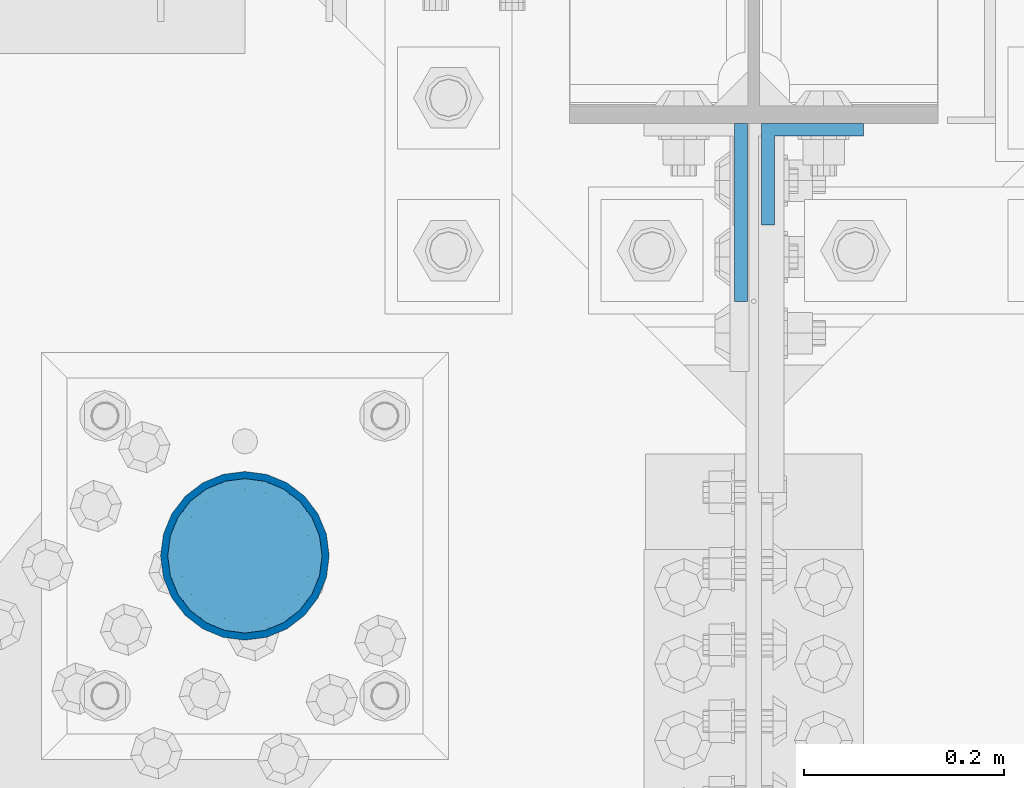
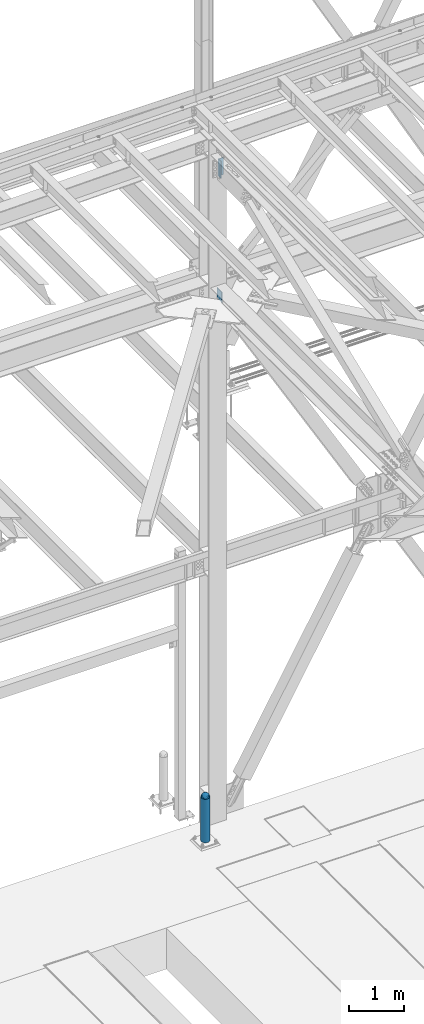
# One storey, part 1584 of 3843: 4 columns, 4 elements without a shape of their own.
"""IFC2X3 building model written with IfcOpenShell, lengths in millimetres."""

from ifc_helpers import new_model, si_unit, frame, origin_with_axes, place, context, subcontext, project, spatial, faceted_brep, material, type_object, element, aggregate, save


model = new_model("IFC2X3")

# Units and contexts
model_context = context("Model", 3, precision=1e-05, world=origin_with_axes())
body_context = subcontext(model_context, "Body", "Model", "MODEL_VIEW")
ifc_project = project(units=[si_unit("LENGTHUNIT", "METRE", prefix="MILLI"), si_unit("AREAUNIT", "SQUARE_METRE"), si_unit("VOLUMEUNIT", "CUBIC_METRE"), si_unit("MASSUNIT", "GRAM", prefix="KILO"), si_unit("TIMEUNIT", "SECOND"), si_unit("PLANEANGLEUNIT", "RADIAN"), si_unit("SOLIDANGLEUNIT", "STERADIAN"), si_unit("THERMODYNAMICTEMPERATUREUNIT", "DEGREE_CELSIUS"), si_unit("LUMINOUSINTENSITYUNIT", "LUMEN")], contexts=[model_context])

# Site, building, storey
site_placement = place(None, origin_with_axes())
site = spatial("IfcSite", under=ifc_project, at=site_placement, CompositionType="ELEMENT")
building_placement = place(site_placement, origin_with_axes())
building = spatial("IfcBuilding", under=site, at=building_placement, Name="Undefined", CompositionType="ELEMENT")
storey_placement = place(building_placement, origin_with_axes())
storey = spatial("IfcBuildingStorey", under=building, at=storey_placement, Name="Undefined", CompositionType="ELEMENT", Elevation=0.0)

# Assembly, column
assembly_1_placement = place(storey_placement, origin_with_axes())
assembly_1 = element("IfcElementAssembly", 1, at=assembly_1_placement, inside=storey, Name="CONC. FILL", AssemblyPlace="NOTDEFINED", PredefinedType="REINFORCEMENT_UNIT")
ifc_material_1 = material(Name="CONCRETE/1500")
column_type_1 = type_object("IfcColumnType", PredefinedType="NOTDEFINED")
column_1_placement = place(assembly_1_placement, frame((48488.6, 91605.1, 31411.8625), z_axis=(-1.0, 0.0, 0.0), x_axis=(0.0, 0.0, 1.0)))
column_1 = element("IfcColumn", 2, at=column_1_placement, type_object=column_type_1, material=ifc_material_1, Name="CONC. FILL", context=body_context, shape_type="Brep", body=[
    faceted_brep([(0.0, 0.0, 2.0), (0.0, -0.619999999995343, 1.89999999999964), (3.36549999999988, -7.1422259999963, 21.9814139999999), (3.36549999999988, 0.0, 23.1139999999996), (0.0, -1.17999999999302, 1.6200000000008), (3.36549999999988, -13.5910319999966, 18.6992260000006), (0.0, -1.61999999999534, 1.18000000000029), (3.36549999999988, -18.699225999997, 13.5910320000003), (0.0, -1.89999999999418, 0.6200000000008), (3.36549999999988, -21.9814139999944, 7.14222599999994), (0.0, -2.0, 0.0), (3.36549999999988, -23.1140000000014, 0.0), (0.0, -1.89999999999418, -0.6200000000008), (3.36549999999988, -21.9814139999944, -7.14222599999994), (0.0, -1.61999999999534, -1.18000000000029), (3.36549999999988, -18.699225999997, -13.5910320000003), (0.0, -1.17999999999302, -1.6200000000008), (3.36549999999988, -13.5910319999966, -18.6992260000006), (0.0, -0.619999999995343, -1.89999999999964), (3.36549999999988, -7.1422259999963, -21.9814139999999), (0.0, 0.0, -2.0), (3.36549999999988, 0.0, -23.1139999999996), (0.0, 0.619999999995343, -1.89999999999964), (3.36549999999988, 7.1422259999963, -21.9814139999999), (0.0, 1.17999999999302, -1.6200000000008), (3.36549999999988, 13.5910319999966, -18.6992260000006), (0.0, 1.61999999999534, -1.18000000000029), (3.36549999999988, 18.699225999997, -13.5910320000003), (0.0, 1.89999999999418, -0.6200000000008), (3.36549999999988, 21.9814139999944, -7.14222599999994), (0.0, 2.0, 0.0), (3.36549999999988, 23.1140000000014, 0.0), (0.0, 1.89999999999418, 0.6200000000008), (3.36549999999988, 21.9814139999944, 7.14222599999994), (0.0, 1.61999999999534, 1.18000000000029), (3.36549999999988, 18.699225999997, 13.5910320000003), (0.0, 1.17999999999302, 1.6200000000008), (3.36549999999988, 13.5910319999966, 18.6992260000006), (0.0, 0.619999999995343, 1.89999999999964), (3.36549999999988, 7.1422259999963, 21.9814139999999), (8.41374999999971, -11.1214661999984, 34.2282018000005), (8.41374999999971, 0.0, 35.9917999999998), (8.41374999999971, -21.1631784000056, 29.1173662000001), (8.41374999999971, -29.1173661999928, 21.1631784000001), (8.41374999999971, -34.2282017999969, 11.1214662000002), (8.41374999999971, -35.9918000000034, 0.0), (8.41374999999971, -34.2282017999969, -11.1214662000002), (8.41374999999971, -29.1173661999928, -21.1631784000001), (8.41374999999971, -21.1631784000056, -29.1173662000001), (8.41374999999971, -11.1214661999984, -34.2282018000005), (8.41374999999971, 0.0, -35.9917999999998), (8.41374999999971, 11.1214661999984, -34.2282018000005), (8.41374999999971, 21.1631784000056, -29.1173662000001), (8.41374999999971, 29.1173661999928, -21.1631784000001), (8.41374999999971, 34.2282017999969, -11.1214662000002), (8.41374999999971, 35.9918000000034, 0.0), (8.41374999999971, 34.2282017999969, 11.1214662000002), (8.41374999999971, 29.1173661999928, 21.1631784000001), (8.41374999999971, 21.1631784000056, 29.1173662000001), (8.41374999999971, 11.1214661999984, 34.2282018000005), (16.8274999999994, -15.3047700000025, 47.1030300000002), (16.8274999999994, 0.0, 49.5300000000007), (16.8274999999994, -29.1236400000053, 40.0697700000001), (16.8274999999994, -40.0697700000019, 29.1236399999998), (16.8274999999994, -47.1030299999984, 15.3047700000006), (16.8274999999994, -49.5299999999988, 0.0), (16.8274999999994, -47.1030299999984, -15.3047700000006), (16.8274999999994, -40.0697700000019, -29.1236399999998), (16.8274999999994, -29.1236400000053, -40.0697700000001), (16.8274999999994, -15.3047700000025, -47.1030300000002), (16.8274999999994, 0.0, -49.5300000000007), (16.8274999999994, 15.3047700000025, -47.1030300000002), (16.8274999999994, 29.1236400000053, -40.0697700000001), (16.8274999999994, 40.0697700000019, -29.1236399999998), (16.8274999999994, 47.1030299999984, -15.3047700000006), (16.8274999999994, 49.5299999999988, 0.0), (16.8274999999994, 47.1030299999984, 15.3047700000006), (16.8274999999994, 40.0697700000019, 29.1236399999998), (16.8274999999994, 29.1236400000053, 40.0697700000001), (16.8274999999994, 15.3047700000025, 47.1030300000002), (33.6549999999988, -20.4063599999936, 62.8040400000009), (33.6549999999988, 0.0, 66.0400000000009), (33.6549999999988, -38.831520000007, 53.4263599999995), (33.6549999999988, -53.4263599999977, 38.8315199999997), (33.6549999999988, -62.8040400000027, 20.4063600000009), (33.6549999999988, -66.0399999999936, 0.0), (33.6549999999988, -62.8040400000027, -20.4063600000009), (33.6549999999988, -53.4263599999977, -38.8315199999997), (33.6549999999988, -38.831520000007, -53.4263599999995), (33.6549999999988, -20.4063599999936, -62.8040400000009), (33.6549999999988, 0.0, -66.0400000000009), (33.6549999999988, 20.4063599999936, -62.8040400000009), (33.6549999999988, 38.831520000007, -53.4263599999995), (33.6549999999988, 53.4263599999977, -38.8315199999997), (33.6549999999988, 62.8040400000027, -20.4063600000009), (33.6549999999988, 66.0399999999936, 0.0), (33.6549999999988, 62.8040400000027, 20.4063600000009), (33.6549999999988, 53.4263599999977, 38.8315199999997), (33.6549999999988, 38.831520000007, 53.4263599999995), (33.6549999999988, 20.4063599999936, 62.8040400000009), (50.4824999999983, -23.3907901500061, 71.9891308499991), (50.4824999999983, 0.0, 75.6983500000006), (50.4824999999983, -44.5106298000028, 61.23996515), (50.4824999999983, -61.2399651500018, 44.5106297999992), (50.4824999999983, -71.9891308499937, 23.3907901500006), (50.4824999999983, -75.698350000006, 0.0), (50.4824999999983, -71.9891308499937, -23.3907901500006), (50.4824999999983, -61.2399651500018, -44.5106297999992), (50.4824999999983, -44.5106298000028, -61.23996515), (50.4824999999983, -23.3907901500061, -71.9891308499991), (50.4824999999983, 0.0, -75.6983500000006), (50.4824999999983, 23.3907901500061, -71.9891308499991), (50.4824999999983, 44.5106298000028, -61.23996515), (50.4824999999983, 61.2399651500018, -44.5106297999992), (50.4824999999983, 71.9891308499937, -23.3907901500006), (50.4824999999983, 75.698350000006, 0.0), (50.4824999999983, 71.9891308499937, 23.3907901500006), (50.4824999999983, 61.2399651500018, 44.5106297999992), (50.4824999999983, 44.5106298000028, 61.23996515), (50.4824999999983, 23.3907901500061, 71.9891308499991), (67.3099999999977, -24.9977910000016, 76.9349490000004), (67.3099999999977, 0.0, 80.8989999999994), (67.3099999999977, -47.5686120000028, 65.4472910000004), (67.3099999999977, -65.447291000004, 47.5686119999991), (67.3099999999977, -76.9349490000022, 24.9977909999998), (67.3099999999977, -80.8990000000049, 0.0), (67.3099999999977, -76.9349490000022, -24.9977909999998), (67.3099999999977, -65.447291000004, -47.5686119999991), (67.3099999999977, -47.5686120000028, -65.4472910000004), (67.3099999999977, -24.9977910000016, -76.9349490000004), (67.3099999999977, 0.0, -80.8989999999994), (67.3099999999977, 24.9977910000016, -76.9349490000004), (67.3099999999977, 47.5686120000028, -65.4472910000004), (67.3099999999977, 65.447291000004, -47.5686119999991), (67.3099999999977, 76.9349490000022, -24.9977909999998), (67.3099999999977, 80.8990000000049, 0.0), (67.3099999999977, 76.9349490000022, 24.9977909999998), (67.3099999999977, 65.447291000004, 47.5686119999991), (67.3099999999977, 47.5686120000028, 65.4472910000004), (67.3099999999977, 24.9977910000016, 76.9349490000004), (84.1374999999935, -25.5079499999993, 78.5050499999998), (84.1374999999935, 0.0, 82.5499999999993), (84.1374999999935, -48.5393999999942, 66.7829500000007), (84.1374999999935, -66.7829499999934, 48.5393999999997), (84.1374999999935, -78.505050000007, 25.5079499999993), (84.1374999999935, -82.5500000000029, 0.0), (84.1374999999935, -78.505050000007, -25.5079499999993), (84.1374999999935, -66.7829499999934, -48.5393999999997), (84.1374999999935, -48.5393999999942, -66.7829500000007), (84.1374999999935, -25.5079499999993, -78.5050499999998), (84.1374999999935, 0.0, -82.5499999999993), (84.1374999999935, 25.5079499999993, -78.5050499999998), (84.1374999999935, 48.5393999999942, -66.7829500000007), (84.1374999999935, 66.7829499999934, -48.5393999999997), (84.1374999999935, 78.505050000007, -25.5079499999993), (84.1374999999935, 82.5500000000029, 0.0), (84.1374999999935, 78.505050000007, 25.5079499999993), (84.1374999999935, 66.7829499999934, 48.5393999999997), (84.1374999999935, 48.5393999999942, 66.7829500000007), (84.1374999999935, 25.5079499999993, 78.5050499999998), (100.964999999993, -24.9977910000016, 76.9349490000004), (100.964999999993, 0.0, 80.8989999999994), (100.964999999993, -47.5686120000028, 65.4472910000004), (100.964999999993, -65.447291000004, 47.5686119999991), (100.964999999993, -76.9349490000022, 24.9977909999998), (100.964999999993, -80.8990000000049, 0.0), (100.964999999993, -76.9349490000022, -24.9977909999998), (100.964999999993, -65.447291000004, -47.5686119999991), (100.964999999993, -47.5686120000028, -65.4472910000004), (100.964999999993, -24.9977910000016, -76.9349490000004), (100.964999999993, 0.0, -80.8989999999994), (100.964999999993, 24.9977910000016, -76.9349490000004), (100.964999999993, 47.5686120000028, -65.4472910000004), (100.964999999993, 65.447291000004, -47.5686119999991), (100.964999999993, 76.9349490000022, -24.9977909999998), (100.964999999993, 80.8990000000049, 0.0), (100.964999999993, 76.9349490000022, 24.9977909999998), (100.964999999993, 65.447291000004, 47.5686119999991), (100.964999999993, 47.5686120000028, 65.4472910000004), (100.964999999993, 24.9977910000016, 76.9349490000004), (117.792499999992, -23.3907901500061, 71.9891308499991), (117.792499999992, 0.0, 75.6983500000006), (117.792499999992, -44.5106298000028, 61.23996515), (117.792499999992, -61.2399651500018, 44.5106297999992), (117.792499999992, -71.9891308499937, 23.3907901500006), (117.792499999992, -75.698350000006, 0.0), (117.792499999992, -71.9891308499937, -23.3907901500006), (117.792499999992, -61.2399651500018, -44.5106297999992), (117.792499999992, -44.5106298000028, -61.23996515), (117.792499999992, -23.3907901500061, -71.9891308499991), (117.792499999992, 0.0, -75.6983500000006), (117.792499999992, 23.3907901500061, -71.9891308499991), (117.792499999992, 44.5106298000028, -61.23996515), (117.792499999992, 61.2399651500018, -44.5106297999992), (117.792499999992, 71.9891308499937, -23.3907901500006), (117.792499999992, 75.698350000006, 0.0), (117.792499999992, 71.9891308499937, 23.3907901500006), (117.792499999992, 61.2399651500018, 44.5106297999992), (117.792499999992, 44.5106298000028, 61.23996515), (117.792499999992, 23.3907901500061, 71.9891308499991), (134.619999999992, -20.4063599999936, 62.8040400000009), (134.619999999992, 0.0, 66.0400000000009), (134.619999999992, -38.831520000007, 53.4263599999995), (134.619999999992, -53.4263599999977, 38.8315199999997), (134.619999999992, -62.8040400000027, 20.4063600000009), (134.619999999992, -66.0399999999936, 0.0), (134.619999999992, -62.8040400000027, -20.4063600000009), (134.619999999992, -53.4263599999977, -38.8315199999997), (134.619999999992, -38.831520000007, -53.4263599999995), (134.619999999992, -20.4063599999936, -62.8040400000009), (134.619999999992, 0.0, -66.0400000000009), (134.619999999992, 20.4063599999936, -62.8040400000009), (134.619999999992, 38.831520000007, -53.4263599999995), (134.619999999992, 53.4263599999977, -38.8315199999997), (134.619999999992, 62.8040400000027, -20.4063600000009), (134.619999999992, 66.0399999999936, 0.0), (134.619999999992, 62.8040400000027, 20.4063600000009), (134.619999999992, 53.4263599999977, 38.8315199999997), (134.619999999992, 38.831520000007, 53.4263599999995), (134.619999999992, 20.4063599999936, 62.8040400000009), (151.447499999991, -15.3047700000025, 47.1030300000002), (151.447499999991, 0.0, 49.5300000000007), (151.447499999991, -29.1236400000053, 40.0697700000001), (151.447499999991, -40.0697700000019, 29.1236399999998), (151.447499999991, -47.1030299999984, 15.3047700000006), (151.447499999991, -49.5299999999988, 0.0), (151.447499999991, -47.1030299999984, -15.3047700000006), (151.447499999991, -40.0697700000019, -29.1236399999998), (151.447499999991, -29.1236400000053, -40.0697700000001), (151.447499999991, -15.3047700000025, -47.1030300000002), (151.447499999991, 0.0, -49.5300000000007), (151.447499999991, 15.3047700000025, -47.1030300000002), (151.447499999991, 29.1236400000053, -40.0697700000001), (151.447499999991, 40.0697700000019, -29.1236399999998), (151.447499999991, 47.1030299999984, -15.3047700000006), (151.447499999991, 49.5299999999988, 0.0), (151.447499999991, 47.1030299999984, 15.3047700000006), (151.447499999991, 40.0697700000019, 29.1236399999998), (151.447499999991, 29.1236400000053, 40.0697700000001), (151.447499999991, 15.3047700000025, 47.1030300000002), (159.861249999991, -11.1214661999984, 34.2282018000005), (159.861249999991, 0.0, 35.9917999999998), (159.861249999991, -21.1631784000056, 29.1173662000001), (159.861249999991, -29.1173661999928, 21.1631784000001), (159.861249999991, -34.2282017999969, 11.1214662000002), (159.861249999991, -35.9918000000034, 0.0), (159.861249999991, -34.2282017999969, -11.1214662000002), (159.861249999991, -29.1173661999928, -21.1631784000001), (159.861249999991, -21.1631784000056, -29.1173662000001), (159.861249999991, -11.1214661999984, -34.2282018000005), (159.861249999991, 0.0, -35.9917999999998), (159.861249999991, 11.1214661999984, -34.2282018000005), (159.861249999991, 21.1631784000056, -29.1173662000001), (159.861249999991, 29.1173661999928, -21.1631784000001), (159.861249999991, 34.2282017999969, -11.1214662000002), (159.861249999991, 35.9918000000034, 0.0), (159.861249999991, 34.2282017999969, 11.1214662000002), (159.861249999991, 29.1173661999928, 21.1631784000001), (159.861249999991, 21.1631784000056, 29.1173662000001), (159.861249999991, 11.1214661999984, 34.2282018000005), (164.909499999991, -7.1422259999963, 21.9814139999999), (164.909499999991, 0.0, 23.1139999999996), (164.909499999991, -13.5910319999966, 18.6992260000006), (164.909499999991, -18.699225999997, 13.5910320000003), (164.909499999991, -21.9814139999944, 7.14222599999994), (164.909499999991, -23.1140000000014, 0.0), (164.909499999991, -21.9814139999944, -7.14222599999994), (164.909499999991, -18.699225999997, -13.5910320000003), (164.909499999991, -13.5910319999966, -18.6992260000006), (164.909499999991, -7.1422259999963, -21.9814139999999), (164.909499999991, 0.0, -23.1139999999996), (164.909499999991, 7.1422259999963, -21.9814139999999), (164.909499999991, 13.5910319999966, -18.6992260000006), (164.909499999991, 18.699225999997, -13.5910320000003), (164.909499999991, 21.9814139999944, -7.14222599999994), (164.909499999991, 23.1140000000014, 0.0), (164.909499999991, 21.9814139999944, 7.14222599999994), (164.909499999991, 18.699225999997, 13.5910320000003), (164.909499999991, 13.5910319999966, 18.6992260000006), (164.909499999991, 7.1422259999963, 21.9814139999999), (168.274999999991, -0.619999999995343, 1.89999999999964), (168.274999999991, 0.0, 2.0), (168.274999999991, -1.17999999999302, 1.6200000000008), (168.274999999991, -1.61999999999534, 1.18000000000029), (168.274999999991, -1.89999999999418, 0.6200000000008), (168.274999999991, -2.0, 0.0), (168.274999999991, -1.89999999999418, -0.6200000000008), (168.274999999991, -1.61999999999534, -1.18000000000029), (168.274999999991, -1.17999999999302, -1.6200000000008), (168.274999999991, -0.619999999995343, -1.89999999999964), (168.274999999991, 0.0, -2.0), (168.274999999991, 0.619999999995343, -1.89999999999964), (168.274999999991, 1.17999999999302, -1.6200000000008), (168.274999999991, 1.61999999999534, -1.18000000000029), (168.274999999991, 1.89999999999418, -0.6200000000008), (168.274999999991, 2.0, 0.0), (168.274999999991, 1.89999999999418, 0.6200000000008), (168.274999999991, 1.61999999999534, 1.18000000000029), (168.274999999991, 1.17999999999302, 1.6200000000008), (168.274999999991, 0.619999999995343, 1.89999999999964)], [[[0, 1, 2, 3]], [[1, 4, 5, 2]], [[4, 6, 7, 5]], [[6, 8, 9, 7]], [[8, 10, 11, 9]], [[10, 12, 13, 11]], [[12, 14, 15, 13]], [[14, 16, 17, 15]], [[16, 18, 19, 17]], [[18, 20, 21, 19]], [[20, 22, 23, 21]], [[22, 24, 25, 23]], [[24, 26, 27, 25]], [[26, 28, 29, 27]], [[28, 30, 31, 29]], [[30, 32, 33, 31]], [[32, 34, 35, 33]], [[34, 36, 37, 35]], [[36, 38, 39, 37]], [[38, 0, 3, 39]], [[38, 36, 34, 32, 30, 28, 26, 24, 22, 20, 18, 16, 14, 12, 10, 8, 6, 4, 1, 0]], [[3, 2, 40, 41]], [[2, 5, 42, 40]], [[5, 7, 43, 42]], [[7, 9, 44, 43]], [[9, 11, 45, 44]], [[11, 13, 46, 45]], [[13, 15, 47, 46]], [[15, 17, 48, 47]], [[17, 19, 49, 48]], [[19, 21, 50, 49]], [[21, 23, 51, 50]], [[23, 25, 52, 51]], [[25, 27, 53, 52]], [[27, 29, 54, 53]], [[29, 31, 55, 54]], [[31, 33, 56, 55]], [[33, 35, 57, 56]], [[35, 37, 58, 57]], [[37, 39, 59, 58]], [[39, 3, 41, 59]], [[41, 40, 60, 61]], [[40, 42, 62, 60]], [[42, 43, 63, 62]], [[43, 44, 64, 63]], [[44, 45, 65, 64]], [[45, 46, 66, 65]], [[46, 47, 67, 66]], [[47, 48, 68, 67]], [[48, 49, 69, 68]], [[49, 50, 70, 69]], [[50, 51, 71, 70]], [[51, 52, 72, 71]], [[52, 53, 73, 72]], [[53, 54, 74, 73]], [[54, 55, 75, 74]], [[55, 56, 76, 75]], [[56, 57, 77, 76]], [[57, 58, 78, 77]], [[58, 59, 79, 78]], [[59, 41, 61, 79]], [[61, 60, 80, 81]], [[60, 62, 82, 80]], [[62, 63, 83, 82]], [[63, 64, 84, 83]], [[64, 65, 85, 84]], [[65, 66, 86, 85]], [[66, 67, 87, 86]], [[67, 68, 88, 87]], [[68, 69, 89, 88]], [[69, 70, 90, 89]], [[70, 71, 91, 90]], [[71, 72, 92, 91]], [[72, 73, 93, 92]], [[73, 74, 94, 93]], [[74, 75, 95, 94]], [[75, 76, 96, 95]], [[76, 77, 97, 96]], [[77, 78, 98, 97]], [[78, 79, 99, 98]], [[79, 61, 81, 99]], [[81, 80, 100, 101]], [[80, 82, 102, 100]], [[82, 83, 103, 102]], [[83, 84, 104, 103]], [[84, 85, 105, 104]], [[85, 86, 106, 105]], [[86, 87, 107, 106]], [[87, 88, 108, 107]], [[88, 89, 109, 108]], [[89, 90, 110, 109]], [[90, 91, 111, 110]], [[91, 92, 112, 111]], [[92, 93, 113, 112]], [[93, 94, 114, 113]], [[94, 95, 115, 114]], [[95, 96, 116, 115]], [[96, 97, 117, 116]], [[97, 98, 118, 117]], [[98, 99, 119, 118]], [[99, 81, 101, 119]], [[101, 100, 120, 121]], [[100, 102, 122, 120]], [[102, 103, 123, 122]], [[103, 104, 124, 123]], [[104, 105, 125, 124]], [[105, 106, 126, 125]], [[106, 107, 127, 126]], [[107, 108, 128, 127]], [[108, 109, 129, 128]], [[109, 110, 130, 129]], [[110, 111, 131, 130]], [[111, 112, 132, 131]], [[112, 113, 133, 132]], [[113, 114, 134, 133]], [[114, 115, 135, 134]], [[115, 116, 136, 135]], [[116, 117, 137, 136]], [[117, 118, 138, 137]], [[118, 119, 139, 138]], [[119, 101, 121, 139]], [[121, 120, 140, 141]], [[120, 122, 142, 140]], [[122, 123, 143, 142]], [[123, 124, 144, 143]], [[124, 125, 145, 144]], [[125, 126, 146, 145]], [[126, 127, 147, 146]], [[127, 128, 148, 147]], [[128, 129, 149, 148]], [[129, 130, 150, 149]], [[130, 131, 151, 150]], [[131, 132, 152, 151]], [[132, 133, 153, 152]], [[133, 134, 154, 153]], [[134, 135, 155, 154]], [[135, 136, 156, 155]], [[136, 137, 157, 156]], [[137, 138, 158, 157]], [[138, 139, 159, 158]], [[139, 121, 141, 159]], [[141, 140, 160, 161]], [[140, 142, 162, 160]], [[142, 143, 163, 162]], [[143, 144, 164, 163]], [[144, 145, 165, 164]], [[145, 146, 166, 165]], [[146, 147, 167, 166]], [[147, 148, 168, 167]], [[148, 149, 169, 168]], [[149, 150, 170, 169]], [[150, 151, 171, 170]], [[151, 152, 172, 171]], [[152, 153, 173, 172]], [[153, 154, 174, 173]], [[154, 155, 175, 174]], [[155, 156, 176, 175]], [[156, 157, 177, 176]], [[157, 158, 178, 177]], [[158, 159, 179, 178]], [[159, 141, 161, 179]], [[161, 160, 180, 181]], [[160, 162, 182, 180]], [[162, 163, 183, 182]], [[163, 164, 184, 183]], [[164, 165, 185, 184]], [[165, 166, 186, 185]], [[166, 167, 187, 186]], [[167, 168, 188, 187]], [[168, 169, 189, 188]], [[169, 170, 190, 189]], [[170, 171, 191, 190]], [[171, 172, 192, 191]], [[172, 173, 193, 192]], [[173, 174, 194, 193]], [[174, 175, 195, 194]], [[175, 176, 196, 195]], [[176, 177, 197, 196]], [[177, 178, 198, 197]], [[178, 179, 199, 198]], [[179, 161, 181, 199]], [[181, 180, 200, 201]], [[180, 182, 202, 200]], [[182, 183, 203, 202]], [[183, 184, 204, 203]], [[184, 185, 205, 204]], [[185, 186, 206, 205]], [[186, 187, 207, 206]], [[187, 188, 208, 207]], [[188, 189, 209, 208]], [[189, 190, 210, 209]], [[190, 191, 211, 210]], [[191, 192, 212, 211]], [[192, 193, 213, 212]], [[193, 194, 214, 213]], [[194, 195, 215, 214]], [[195, 196, 216, 215]], [[196, 197, 217, 216]], [[197, 198, 218, 217]], [[198, 199, 219, 218]], [[199, 181, 201, 219]], [[201, 200, 220, 221]], [[200, 202, 222, 220]], [[202, 203, 223, 222]], [[203, 204, 224, 223]], [[204, 205, 225, 224]], [[205, 206, 226, 225]], [[206, 207, 227, 226]], [[207, 208, 228, 227]], [[208, 209, 229, 228]], [[209, 210, 230, 229]], [[210, 211, 231, 230]], [[211, 212, 232, 231]], [[212, 213, 233, 232]], [[213, 214, 234, 233]], [[214, 215, 235, 234]], [[215, 216, 236, 235]], [[216, 217, 237, 236]], [[217, 218, 238, 237]], [[218, 219, 239, 238]], [[219, 201, 221, 239]], [[221, 220, 240, 241]], [[220, 222, 242, 240]], [[222, 223, 243, 242]], [[223, 224, 244, 243]], [[224, 225, 245, 244]], [[225, 226, 246, 245]], [[226, 227, 247, 246]], [[227, 228, 248, 247]], [[228, 229, 249, 248]], [[229, 230, 250, 249]], [[230, 231, 251, 250]], [[231, 232, 252, 251]], [[232, 233, 253, 252]], [[233, 234, 254, 253]], [[234, 235, 255, 254]], [[235, 236, 256, 255]], [[236, 237, 257, 256]], [[237, 238, 258, 257]], [[238, 239, 259, 258]], [[239, 221, 241, 259]], [[241, 240, 260, 261]], [[240, 242, 262, 260]], [[242, 243, 263, 262]], [[243, 244, 264, 263]], [[244, 245, 265, 264]], [[245, 246, 266, 265]], [[246, 247, 267, 266]], [[247, 248, 268, 267]], [[248, 249, 269, 268]], [[249, 250, 270, 269]], [[250, 251, 271, 270]], [[251, 252, 272, 271]], [[252, 253, 273, 272]], [[253, 254, 274, 273]], [[254, 255, 275, 274]], [[255, 256, 276, 275]], [[256, 257, 277, 276]], [[257, 258, 278, 277]], [[258, 259, 279, 278]], [[259, 241, 261, 279]], [[261, 260, 280, 281]], [[260, 262, 282, 280]], [[262, 263, 283, 282]], [[263, 264, 284, 283]], [[264, 265, 285, 284]], [[265, 266, 286, 285]], [[266, 267, 287, 286]], [[267, 268, 288, 287]], [[268, 269, 289, 288]], [[269, 270, 290, 289]], [[270, 271, 291, 290]], [[271, 272, 292, 291]], [[272, 273, 293, 292]], [[273, 274, 294, 293]], [[274, 275, 295, 294]], [[275, 276, 296, 295]], [[276, 277, 297, 296]], [[277, 278, 298, 297]], [[278, 279, 299, 298]], [[279, 261, 281, 299]], [[282, 283, 284, 285, 286, 287, 288, 289, 290, 291, 292, 293, 294, 295, 296, 297, 298, 299, 281, 280]]]),
])
aggregate(assembly_1, [column_1])

assembly_2_placement = place(storey_placement, origin_with_axes())
assembly_2 = element("IfcElementAssembly", 3, at=assembly_2_placement, inside=storey, Name="PIPE_BOLLARD", AssemblyPlace="NOTDEFINED", PredefinedType="RIGID_FRAME")
ifc_material_2 = material()
column_type_2 = type_object("IfcColumnType", Name="PIPE6SCH40", PredefinedType="NOTDEFINED")
column_2_placement = place(assembly_2_placement, frame((48488.6, 91605.1, 30480.0), z_axis=(-1.0, 0.0, 0.0), x_axis=(0.0, 0.0, 1.0)))
column_2 = element("IfcColumn", 4, at=column_2_placement, type_object=column_type_2, material=ifc_material_2, Name="PIPE_BOLLARD", ObjectType="PIPE6SCH40", context=body_context, shape_type="Brep", body=[
    faceted_brep([(50.7999999999993, -77.0890000000072, 0.0), (50.7999999999993, -74.4622560228017, 19.9521013679114), (1016.0, -74.4622560228017, 19.9521013679114), (1016.0, -77.0890000000072, 0.0), (50.7999999999993, -66.7610323523404, 38.5445000000036), (1016.0, -66.7610323523404, 38.5445000000036), (50.7999999999993, -54.5101546548831, 54.5101546548904), (1016.0, -54.5101546548831, 54.5101546548904), (50.7999999999993, -38.5445000000036, 66.7610323523404), (1016.0, -38.5445000000036, 66.7610323523404), (50.7999999999993, -19.9521013679041, 74.4622560227945), (1016.0, -19.9521013679041, 74.4622560227945), (50.7999999999993, 0.0, 77.0889999999999), (1016.0, 0.0, 77.0889999999999), (50.7999999999993, 19.9521013679041, 74.4622560227945), (1016.0, 19.9521013679041, 74.4622560227945), (50.7999999999993, 38.5445000000036, 66.7610323523404), (1016.0, 38.5445000000036, 66.7610323523404), (50.7999999999993, 54.5101546548831, 54.5101546548904), (1016.0, 54.5101546548831, 54.5101546548904), (50.7999999999993, 66.7610323523404, 38.5445000000036), (1016.0, 66.7610323523404, 38.5445000000036), (50.7999999999993, 74.4622560228017, 19.9521013679114), (1016.0, 74.4622560228017, 19.9521013679114), (50.7999999999993, 77.0890000000072, 0.0), (1016.0, 77.0890000000072, 0.0), (50.7999999999993, 74.4622560228017, -19.9521013679114), (1016.0, 74.4622560228017, -19.9521013679114), (50.7999999999993, 66.7610323523404, -38.5445000000036), (1016.0, 66.7610323523404, -38.5445000000036), (50.7999999999993, 54.5101546548831, -54.5101546548904), (1016.0, 54.5101546548831, -54.5101546548904), (50.7999999999993, 38.5445000000036, -66.7610323523404), (1016.0, 38.5445000000036, -66.7610323523404), (50.7999999999993, 19.9521013679041, -74.4622560227945), (1016.0, 19.9521013679041, -74.4622560227945), (50.7999999999993, 0.0, -77.0889999999999), (1016.0, 0.0, -77.0889999999999), (50.7999999999993, -19.9521013679041, -74.4622560227945), (1016.0, -19.9521013679041, -74.4622560227945), (50.7999999999993, -38.5445000000036, -66.7610323523404), (1016.0, -38.5445000000036, -66.7610323523404), (50.7999999999993, -54.5101546548831, -54.5101546548904), (1016.0, -54.5101546548831, -54.5101546548904), (50.7999999999993, -66.7610323523404, -38.5445000000036), (1016.0, -66.7610323523404, -38.5445000000036), (50.7999999999993, -74.4622560228017, -19.9521013679114), (1016.0, -74.4622560228017, -19.9521013679114), (50.7999999999993, -84.2010000000009, 0.0), (50.7999999999993, -81.3319204993604, -21.7928224166753), (1016.0, -81.3319204993604, -21.7928224166753), (1016.0, -84.2010000000009, 0.0), (50.7999999999993, -72.9202050240565, -42.1005000000005), (1016.0, -72.9202050240565, -42.1005000000005), (50.7999999999993, -59.5390980826924, -59.5390980826851), (1016.0, -59.5390980826924, -59.5390980826851), (50.7999999999993, -42.1005000000005, -72.9202050240565), (1016.0, -42.1005000000005, -72.9202050240565), (50.7999999999993, -21.7928224166826, -81.3319204993677), (1016.0, -21.7928224166826, -81.3319204993677), (50.7999999999993, 0.0, -84.2010000000009), (1016.0, 0.0, -84.2010000000009), (50.7999999999993, 21.7928224166826, -81.3319204993677), (1016.0, 21.7928224166826, -81.3319204993677), (50.7999999999993, 42.1005000000005, -72.9202050240565), (1016.0, 42.1005000000005, -72.9202050240565), (50.7999999999993, 59.5390980826924, -59.5390980826851), (1016.0, 59.5390980826924, -59.5390980826851), (50.7999999999993, 72.9202050240565, -42.1005000000005), (1016.0, 72.9202050240565, -42.1005000000005), (50.7999999999993, 81.3319204993604, -21.7928224166753), (1016.0, 81.3319204993604, -21.7928224166753), (50.7999999999993, 84.2010000000009, 0.0), (1016.0, 84.2010000000009, 0.0), (50.7999999999993, 81.3319204993604, 21.7928224166753), (1016.0, 81.3319204993604, 21.7928224166753), (50.7999999999993, 72.9202050240565, 42.1005000000005), (1016.0, 72.9202050240565, 42.1005000000005), (50.7999999999993, 59.5390980826924, 59.5390980826851), (1016.0, 59.5390980826924, 59.5390980826851), (50.7999999999993, 42.1005000000005, 72.9202050240565), (1016.0, 42.1005000000005, 72.9202050240565), (50.7999999999993, 21.7928224166826, 81.3319204993677), (1016.0, 21.7928224166826, 81.3319204993677), (50.7999999999993, 0.0, 84.2010000000009), (1016.0, 0.0, 84.2010000000009), (50.7999999999993, -21.7928224166826, 81.3319204993677), (1016.0, -21.7928224166826, 81.3319204993677), (50.7999999999993, -42.1005000000005, 72.9202050240565), (1016.0, -42.1005000000005, 72.9202050240565), (50.7999999999993, -59.5390980826924, 59.5390980826851), (1016.0, -59.5390980826924, 59.5390980826851), (50.7999999999993, -72.9202050240565, 42.1005000000005), (1016.0, -72.9202050240565, 42.1005000000005), (50.7999999999993, -81.3319204993604, 21.7928224166753), (1016.0, -81.3319204993604, 21.7928224166753)], [[[0, 1, 2, 3]], [[1, 4, 5, 2]], [[4, 6, 7, 5]], [[6, 8, 9, 7]], [[8, 10, 11, 9]], [[10, 12, 13, 11]], [[12, 14, 15, 13]], [[14, 16, 17, 15]], [[16, 18, 19, 17]], [[18, 20, 21, 19]], [[20, 22, 23, 21]], [[22, 24, 25, 23]], [[24, 26, 27, 25]], [[26, 28, 29, 27]], [[28, 30, 31, 29]], [[30, 32, 33, 31]], [[32, 34, 35, 33]], [[34, 36, 37, 35]], [[36, 38, 39, 37]], [[38, 40, 41, 39]], [[40, 42, 43, 41]], [[42, 44, 45, 43]], [[44, 46, 47, 45]], [[46, 0, 3, 47]], [[48, 49, 50, 51]], [[49, 52, 53, 50]], [[52, 54, 55, 53]], [[54, 56, 57, 55]], [[56, 58, 59, 57]], [[58, 60, 61, 59]], [[60, 62, 63, 61]], [[62, 64, 65, 63]], [[64, 66, 67, 65]], [[66, 68, 69, 67]], [[68, 70, 71, 69]], [[70, 72, 73, 71]], [[72, 74, 75, 73]], [[74, 76, 77, 75]], [[76, 78, 79, 77]], [[78, 80, 81, 79]], [[80, 82, 83, 81]], [[82, 84, 85, 83]], [[84, 86, 87, 85]], [[86, 88, 89, 87]], [[88, 90, 91, 89]], [[90, 92, 93, 91]], [[92, 94, 95, 93]], [[94, 48, 51, 95]], [[53, 55, 57, 59, 61, 63, 65, 67, 69, 71, 73, 75, 77, 79, 81, 83, 85, 87, 89, 91, 93, 95, 51, 50], [5, 7, 9, 11, 13, 15, 17, 19, 21, 23, 25, 27, 29, 31, 33, 35, 37, 39, 41, 43, 45, 47, 3, 2]], [[94, 92, 90, 88, 86, 84, 82, 80, 78, 76, 74, 72, 70, 68, 66, 64, 62, 60, 58, 56, 54, 52, 49, 48], [46, 44, 42, 40, 38, 36, 34, 32, 30, 28, 26, 24, 22, 20, 18, 16, 14, 12, 10, 8, 6, 4, 1, 0]]]),
])
aggregate(assembly_2, [column_2])

assembly_3_placement = place(storey_placement, origin_with_axes())
assembly_3 = element("IfcElementAssembly", 5, at=assembly_3_placement, inside=storey, Name="COLUMN", AssemblyPlace="NOTDEFINED", PredefinedType="RIGID_FRAME")
ifc_material_3 = material(Name="STEEL/A572-50")
column_type_3 = type_object("IfcColumnType", PredefinedType="NOTDEFINED")
column_3_placement = place(assembly_3_placement, frame((48983.9, 91948.0290000007, 42130.8337090741), z_axis=(0.0, 1.0, 0.0), x_axis=(0.0, 0.0, 1.0)))
column_3 = element("IfcColumn", 6, at=column_3_placement, type_object=column_type_3, material=ifc_material_3, Name="PLATE", context=body_context, shape_type="Brep", body=[
    faceted_brep([(0.0, 6.34999999999854, -88.8709999999992), (0.0, 6.34999999999854, 88.8709999999992), (228.599999999999, 6.34999999999854, 88.8709999999992), (228.599999999999, 6.34999999999854, -88.8709999999992), (0.0, -6.34999999999854, 88.8709999999992), (228.599999999999, -6.34999999999854, 88.8709999999992), (0.0, -6.34999999999854, -88.8709999999992), (228.599999999999, -6.34999999999854, -88.8709999999992)], [[[0, 1, 2, 3]], [[1, 4, 5, 2]], [[4, 6, 7, 5]], [[6, 0, 3, 7]], [[5, 7, 3, 2]], [[6, 4, 1, 0]]]),
])
aggregate(assembly_3, [column_3])

assembly_4_placement = place(storey_placement, origin_with_axes())
assembly_4 = element("IfcElementAssembly", 7, at=assembly_4_placement, inside=storey, Name="PLATE", AssemblyPlace="NOTDEFINED", PredefinedType="RIGID_FRAME")
column_type_4 = type_object("IfcColumnType", Name="L4X4X1/2", PredefinedType="NOTDEFINED")
column_4_placement = place(assembly_4_placement, frame((49055.3375000006, 91986.1000000629, 44821.9146634992), z_axis=(0.0, -1.0, 0.0), x_axis=(0.0, 0.0, 1.0)))
column_4 = element("IfcColumn", 8, at=column_4_placement, type_object=column_type_4, material=ifc_material_3, Name="ANGLE", ObjectType="L4X4X1/2", context=body_context, shape_type="Brep", body=[
    faceted_brep([(0.0, 50.8000000000029, -50.8000000000029), (0.0, 50.8000000000029, 50.8000000000029), (381.0, 50.8000000000029, 50.8000000000029), (381.0, 50.8000000000029, -50.8000000000029), (0.0, 38.0999999999985, 50.8000000000029), (381.0, 38.0999999999985, 50.8000000000029), (0.0, 38.0999999999985, -38.0999999999985), (381.0, 38.0999999999985, -38.1000000000058), (0.0, -50.8000000000029, -38.1000000000058), (381.0, -50.8000000000029, -38.1000000000058), (0.0, -50.8000000000029, -50.8000000000029), (381.0, -50.8000000000029, -50.8000000000029)], [[[0, 1, 2, 3]], [[1, 4, 5, 2]], [[4, 6, 7, 5]], [[6, 8, 9, 7]], [[8, 10, 11, 9]], [[10, 0, 3, 11]], [[5, 7, 9, 11, 3, 2]], [[10, 8, 6, 4, 1, 0]]]),
])
aggregate(assembly_4, [column_4])

save(model, "model.ifc")
